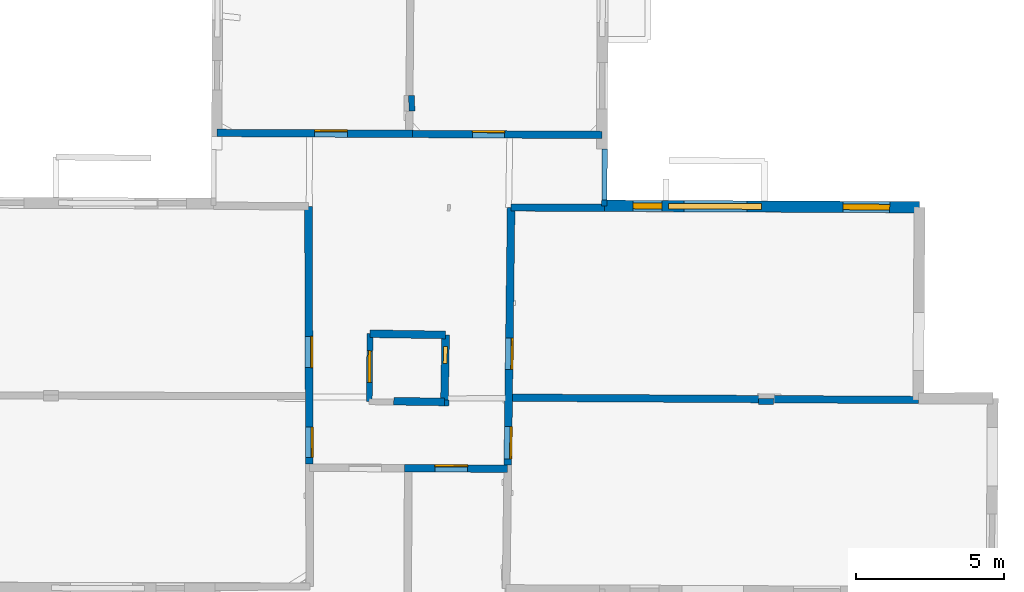
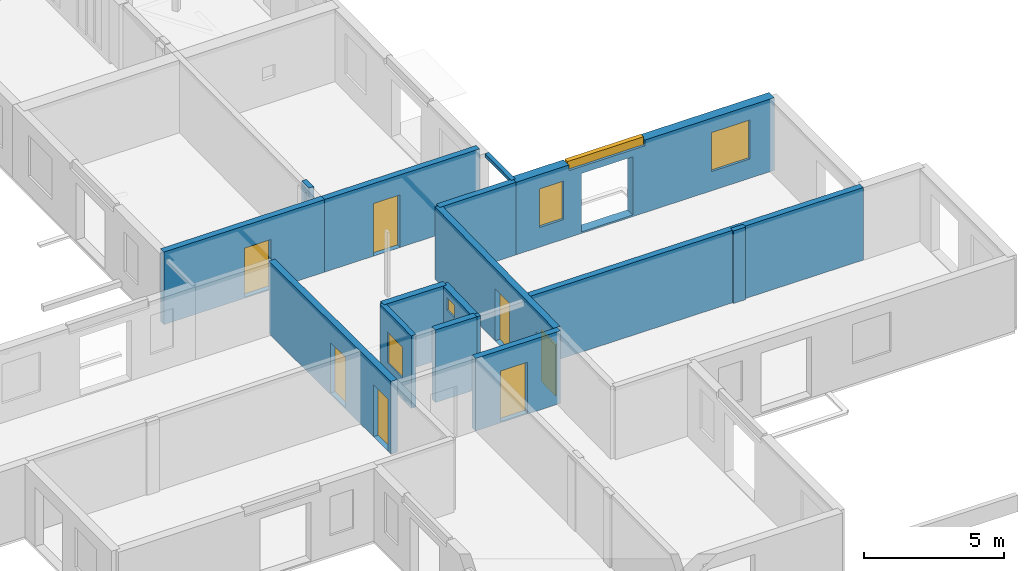
# One storey, part 5 of 17: 16 walls, 7 doors, 5 windows, 14 openings.
"""IFC2X3 building model written with IfcOpenShell, lengths in metres."""

from ifc_helpers import new_model, entity, si_unit, converted_unit, derived_unit, direction, frame, frame_2d, origin, origin_2d_with_axis, place, context, subcontext, project, spatial, polyline, rectangle, outline, extrude, source, transform, mapped, material, layer, layer_set, layer_usage, type_object, type_shapes, element, fill, save


model = new_model("IFC2X3")

# Units and contexts
model_context = context("Model", 3, precision=1e-05, world=origin(), true_north=direction((0.0, 1.0)))
body_context = subcontext(model_context, "Body", "Model", "MODEL_VIEW")
ifc_project = project(units=[si_unit("LENGTHUNIT", "METRE"), si_unit("AREAUNIT", "SQUARE_METRE"), si_unit("VOLUMEUNIT", "CUBIC_METRE"), converted_unit("PLANEANGLEUNIT", "DEGREE", entity("IfcRatioMeasure", 0.0174532925199433), si_unit("PLANEANGLEUNIT", "RADIAN"), dimensions=[0, 0, 0, 0, 0, 0, 0]), si_unit("MASSUNIT", "GRAM", prefix="KILO"), derived_unit("MASSDENSITYUNIT", [(si_unit("MASSUNIT", "GRAM", prefix="KILO"), 1), (si_unit("LENGTHUNIT", "METRE"), -3)]), derived_unit("MOMENTOFINERTIAUNIT", [(si_unit("LENGTHUNIT", "METRE"), 4)]), si_unit("TIMEUNIT", "SECOND"), si_unit("FREQUENCYUNIT", "HERTZ"), si_unit("THERMODYNAMICTEMPERATUREUNIT", "DEGREE_CELSIUS"), derived_unit("THERMALTRANSMITTANCEUNIT", [(si_unit("MASSUNIT", "GRAM", prefix="KILO"), 1), (si_unit("THERMODYNAMICTEMPERATUREUNIT", "KELVIN"), -1), (si_unit("TIMEUNIT", "SECOND"), -3)]), derived_unit("VOLUMETRICFLOWRATEUNIT", [(si_unit("LENGTHUNIT", "METRE"), 3), (si_unit("TIMEUNIT", "SECOND"), -1)]), si_unit("ELECTRICCURRENTUNIT", "AMPERE"), si_unit("ELECTRICVOLTAGEUNIT", "VOLT"), si_unit("POWERUNIT", "WATT"), si_unit("FORCEUNIT", "NEWTON", prefix="KILO"), si_unit("ILLUMINANCEUNIT", "LUX"), si_unit("LUMINOUSFLUXUNIT", "LUMEN"), si_unit("LUMINOUSINTENSITYUNIT", "CANDELA"), derived_unit("USERDEFINED", [(si_unit("MASSUNIT", "GRAM", prefix="KILO"), -1), (si_unit("LENGTHUNIT", "METRE"), -2), (si_unit("TIMEUNIT", "SECOND"), 3), (si_unit("LUMINOUSFLUXUNIT", "LUMEN"), 1)]), derived_unit("LINEARVELOCITYUNIT", [(si_unit("LENGTHUNIT", "METRE"), 1), (si_unit("TIMEUNIT", "SECOND"), -1)]), si_unit("PRESSUREUNIT", "PASCAL"), derived_unit("USERDEFINED", [(si_unit("LENGTHUNIT", "METRE"), -2), (si_unit("MASSUNIT", "GRAM", prefix="KILO"), 1), (si_unit("TIMEUNIT", "SECOND"), -2)]), derived_unit("LINEARFORCEUNIT", [(si_unit("MASSUNIT", "GRAM", prefix="KILO"), 1), (si_unit("LENGTHUNIT", "METRE"), 1), (si_unit("TIMEUNIT", "SECOND"), -2), (si_unit("LENGTHUNIT", "METRE"), -1)]), derived_unit("PLANARFORCEUNIT", [(si_unit("MASSUNIT", "GRAM", prefix="KILO"), 1), (si_unit("LENGTHUNIT", "METRE"), 1), (si_unit("TIMEUNIT", "SECOND"), -2), (si_unit("LENGTHUNIT", "METRE"), -2)])], contexts=[model_context])

# Site, building, storey
placement = place(None, origin())
site = spatial("IfcSite", under=ifc_project, at=placement, CompositionType="ELEMENT")
building = spatial("IfcBuilding", under=site, at=placement, CompositionType="ELEMENT")
storey_placement = place(placement, frame((0.0, 0.0, 5.56662893295288)))
storey = spatial("IfcBuildingStorey", under=building, at=storey_placement, Name="Level 3", CompositionType="ELEMENT", Elevation=5.56662893295288)

# Wall, opening, door
ifc_material_1 = material(Name="Default wall")
ifc_layer_1 = layer(ifc_material_1, 0.25)
ifc_layer_set_1 = layer_set([ifc_layer_1], Name="wall_thickness_0.2500")
ifc_layer_usage_1 = layer_usage(ifc_layer_set_1, "AXIS2", "POSITIVE", -0.125)
wall_type_1 = type_object("IfcWallType", Name="wall_thickness_0.2500", PredefinedType="STANDARD", material=ifc_layer_set_1)
wall_1_placement = place(storey_placement, frame((6.05652333948294, 17.0406184513723, 0.0), z_axis=(0.0, 0.0, 1.0), x_axis=(0.999988302354351, -0.00483685377732667, 0.0)))
wall_1 = element("IfcWallStandardCase", 1, at=wall_1_placement, inside=storey, type_object=wall_type_1, material=ifc_layer_usage_1, Name="Wall:33", ObjectType="Wall", context=body_context, shape_type="SweptSolid", body=[
    extrude(outline(polyline([(3.48278114256136, -0.125), (3.48278114256136, 0.125), (0.0, 0.125), (0.0, -0.125), (3.48278114256136, -0.125)])), origin(), (0.0, 0.0, 1.0), 3.16489877700806),
])
opening_1_placement = place(wall_1_placement, frame((1.02562006761341, -0.125, 0.0583710670471191)))
opening_1 = element("IfcOpeningElement", 2, at=opening_1_placement, cuts=wall_1, Name="Opening : 1105 x 2205 : 26", ObjectType="Opening", context=body_context, shape_type="SweptSolid", body=[
    extrude(rectangle(XDim=1.105, YDim=2.205, at=frame_2d((1.1025, 0.5525), x_axis=(0.0, 1.0))), frame((0.0, 0.0, 0.0), z_axis=(0.0, 1.0, 0.0), x_axis=(0.0, 0.0, 1.0)), (0.0, 0.0, 1.0), 0.25),
])
ifc_material_2 = material(Name="Door Panel")
door_style_1 = type_object("IfcDoorStyle", Name="Door : 1105 x 2205mm", ConstructionType="NOTDEFINED", OperationType="SINGLE_SWING_RIGHT", ParameterTakesPrecedence=False, Sizeable=False, material=ifc_material_2)
shared_shape_1 = source(origin(), body_context, "Body", "SweptSolid", [
    extrude(rectangle(XDim=0.0625, YDim=1.105, at=origin_2d_with_axis()), frame((0.5525, 0.21875, 0.0), z_axis=(0.0, 0.0, 1.0), x_axis=(0.0, 1.0, 0.0)), (0.0, 0.0, 1.0), 2.205),
])
type_shapes(door_style_1, [shared_shape_1])
door_1_placement = place(opening_1_placement, origin())
door_1 = element("IfcDoor", 3, at=door_1_placement, inside=storey, type_object=door_style_1, Name="Door : 1105 x 2205mm : 6", ObjectType="Door : 1105 x 2205mm", OverallHeight=2.205, OverallWidth=1.105, context=body_context, shape_type="MappedRepresentation", body=[
    mapped(shared_shape_1, transform((0.0, 0.0, 0.0), scale=1.0)),
])
fill(opening_1, door_1)

# Wall
wall_2_placement = place(storey_placement, frame((9.65358275442785, 25.8274997320998, 0.0), z_axis=(0.0, 0.0, 1.0), x_axis=(0.999997260642278, -0.00234066399563864, 0.0)))
element("IfcWallStandardCase", 4, at=wall_2_placement, inside=storey, type_object=wall_type_1, material=ifc_layer_usage_1, Name="Wall:60", ObjectType="Wall", context=body_context, shape_type="SweptSolid", body=[
    extrude(outline(polyline([(3.14297297282543, -0.125), (3.14297297282543, 0.125), (0.0, 0.125), (0.0, -0.125), (3.14297297282543, -0.125)])), origin(), (0.0, 0.0, 1.0), 3.16489877700806),
])

# Wall, opening, door
wall_3_placement = place(storey_placement, frame((-0.266225012666625, 28.3407746540219, 0.0), z_axis=(0.0, 0.0, 1.0), x_axis=(0.999985683935674, -0.00535088064734463, 0.0)))
wall_3 = element("IfcWallStandardCase", 5, at=wall_3_placement, inside=storey, type_object=wall_type_1, material=ifc_layer_usage_1, Name="Wall:98", ObjectType="Wall", context=body_context, shape_type="SweptSolid", body=[
    extrude(outline(polyline([(6.60297405283224, -0.125), (6.60297405283224, 0.125), (0.0, 0.125), (0.0, -0.125), (6.60297405283224, -0.125)])), origin(), (0.0, 0.0, 1.0), 3.16489877700806),
])
opening_2_placement = place(wall_3_placement, frame((3.30106026213288, -0.125, 0.0503711700439453)))
opening_2 = element("IfcOpeningElement", 6, at=opening_2_placement, cuts=wall_3, Name="Opening : 1100 x 2140 : 91", ObjectType="Opening", context=body_context, shape_type="SweptSolid", body=[
    extrude(rectangle(XDim=1.1, YDim=2.14, at=frame_2d((1.07, 0.55), x_axis=(0.0, 1.0))), frame((0.0, 0.0, 0.0), z_axis=(0.0, 1.0, 0.0), x_axis=(0.0, 0.0, 1.0)), (0.0, 0.0, 1.0), 0.25),
])
door_style_2 = type_object("IfcDoorStyle", Name="Door : 1100 x 2140mm", ConstructionType="NOTDEFINED", OperationType="SINGLE_SWING_RIGHT", ParameterTakesPrecedence=False, Sizeable=False, material=ifc_material_2)
shared_shape_2 = source(origin(), body_context, "Body", "SweptSolid", [
    extrude(rectangle(XDim=0.0625, YDim=1.1, at=origin_2d_with_axis()), frame((0.55, 0.21875, 0.0), z_axis=(0.0, 0.0, 1.0), x_axis=(0.0, 1.0, 0.0)), (0.0, 0.0, 1.0), 2.14),
])
type_shapes(door_style_2, [shared_shape_2])
door_2_placement = place(opening_2_placement, origin())
door_2 = element("IfcDoor", 7, at=door_2_placement, inside=storey, type_object=door_style_2, Name="Door : 1100 x 2140mm : 13", ObjectType="Door : 1100 x 2140mm", OverallHeight=2.14, OverallWidth=1.1, context=body_context, shape_type="MappedRepresentation", body=[
    mapped(shared_shape_2, transform((0.0, 0.0, 0.0), scale=1.0)),
])
fill(opening_2, door_2)

wall_4_placement = place(storey_placement, frame((6.33665451156433, 28.3054429279477, 0.0), z_axis=(0.0, 0.0, 1.0), x_axis=(0.999985684537031, -0.00535076826313938, 0.0)))
wall_4 = element("IfcWallStandardCase", 8, at=wall_4_placement, inside=storey, type_object=wall_type_1, material=ifc_layer_usage_1, Name="Wall:99", ObjectType="Wall", context=body_context, shape_type="SweptSolid", body=[
    extrude(outline(polyline([(6.37711546509686, -0.125), (6.37711546509686, 0.125), (0.0, 0.125), (0.0, -0.125), (6.37711546509686, -0.125)])), origin(), (0.0, 0.0, 1.0), 3.16489877700806),
])
opening_3_placement = place(wall_4_placement, frame((2.00841869315561, -0.125, 0.00537109375)))
opening_3 = element("IfcOpeningElement", 9, at=opening_3_placement, cuts=wall_4, Name="Opening : 1090 x 2290 : 92", ObjectType="Opening", context=body_context, shape_type="SweptSolid", body=[
    extrude(rectangle(XDim=1.09, YDim=2.29, at=frame_2d((1.145, 0.545), x_axis=(0.0, 1.0))), frame((0.0, 0.0, 0.0), z_axis=(0.0, 1.0, 0.0), x_axis=(0.0, 0.0, 1.0)), (0.0, 0.0, 1.0), 0.25),
])
door_style_3 = type_object("IfcDoorStyle", Name="Door : 1090 x 2290mm", ConstructionType="NOTDEFINED", OperationType="SINGLE_SWING_RIGHT", ParameterTakesPrecedence=False, Sizeable=False, material=ifc_material_2)
shared_shape_3 = source(origin(), body_context, "Body", "SweptSolid", [
    extrude(rectangle(XDim=0.0625, YDim=1.09, at=origin_2d_with_axis()), frame((0.545, 0.21875, 0.0), z_axis=(0.0, 0.0, 1.0), x_axis=(0.0, 1.0, 0.0)), (0.0, 0.0, 1.0), 2.29),
])
type_shapes(door_style_3, [shared_shape_3])
door_3_placement = place(opening_3_placement, origin())
door_3 = element("IfcDoor", 10, at=door_3_placement, inside=storey, type_object=door_style_3, Name="Door : 1090 x 2290mm : 14", ObjectType="Door : 1090 x 2290mm", OverallHeight=2.29, OverallWidth=1.09, context=body_context, shape_type="MappedRepresentation", body=[
    mapped(shared_shape_3, transform((0.0, 0.0, 0.0), scale=1.0)),
])
fill(opening_3, door_3)

# Wall
wall_5_placement = place(storey_placement, frame((9.62779988573269, 19.4185865706265, 0.0), z_axis=(0.0, 0.0, 1.0), x_axis=(0.999983458236954, -0.00575180427886315, 0.0)))
element("IfcWallStandardCase", 11, at=wall_5_placement, inside=storey, type_object=wall_type_1, material=ifc_layer_usage_1, Name="Wall:112", ObjectType="Wall", context=body_context, shape_type="SweptSolid", body=[
    extrude(outline(polyline([(13.7478355982533, -0.125), (13.7478355982533, 0.125), (0.0, 0.125), (0.0, -0.125), (13.7478355982533, -0.125)])), origin(), (0.0, 0.0, 1.0), 3.16489877700806),
])

# Wall, opening, window
ifc_layer_2 = layer(ifc_material_1, 0.2)
ifc_layer_set_2 = layer_set([ifc_layer_2], Name="wall_thickness_0.2000")
ifc_layer_usage_2 = layer_usage(ifc_layer_set_2, "AXIS2", "POSITIVE", -0.1)
wall_type_2 = type_object("IfcWallType", Name="wall_thickness_0.2000", PredefinedType="STANDARD", material=ifc_layer_set_2)
wall_6_placement = place(storey_placement, frame((4.89663860121221, 21.5726538806311, 0.0), z_axis=(0.0, 0.0, 1.0), x_axis=(-0.0110328218445975, -0.999939136568894, 0.0)))
wall_6 = element("IfcWallStandardCase", 12, at=wall_6_placement, inside=storey, type_object=wall_type_2, material=ifc_layer_usage_2, Name="Wall:6", ObjectType="Wall", context=body_context, shape_type="SweptSolid", body=[
    extrude(outline(polyline([(2.29026428653109, -0.1), (2.29026428653109, 0.1), (0.0, 0.1), (0.0, -0.1), (2.29026428653109, -0.1)])), origin(), (0.0, 0.0, 1.0), 3.16489877700806),
])
opening_4_placement = place(wall_6_placement, frame((0.573237012092791, -0.1, 0.935370922088623)))
opening_4 = element("IfcOpeningElement", 13, at=opening_4_placement, cuts=wall_6, Name="Opening : 1075 x 1345 : 6", ObjectType="Opening", context=body_context, shape_type="SweptSolid", body=[
    extrude(rectangle(XDim=1.075, YDim=1.345, at=frame_2d((0.6725, 0.5375), x_axis=(0.0, 1.0))), frame((0.0, 0.0, 0.0), z_axis=(0.0, 1.0, 0.0), x_axis=(0.0, 0.0, 1.0)), (0.0, 0.0, 1.0), 0.2),
])
ifc_material_3 = material(Name="Window Default")
window_style_1 = type_object("IfcWindowStyle", Name="Window : 1075 x 1345mm", ConstructionType="NOTDEFINED", OperationType="NOTDEFINED", ParameterTakesPrecedence=False, Sizeable=False, material=ifc_material_3)
shared_shape_4 = source(origin(), body_context, "Body", "SweptSolid", [
    extrude(rectangle(XDim=0.1, YDim=1.075, at=origin_2d_with_axis()), frame((0.5375, 0.1, 0.0), z_axis=(0.0, 0.0, 1.0), x_axis=(0.0, 1.0, 0.0)), (0.0, 0.0, 1.0), 1.345),
])
type_shapes(window_style_1, [shared_shape_4])
window_1_placement = place(opening_4_placement, origin())
window_1 = element("IfcWindow", 14, at=window_1_placement, inside=storey, type_object=window_style_1, Name="Window : 1075 x 1345mm : 3", ObjectType="Window : 1075 x 1345mm", OverallHeight=1.345, OverallWidth=1.075, context=body_context, shape_type="MappedRepresentation", body=[
    mapped(shared_shape_4, transform((0.0, 0.0, 0.0), scale=1.0)),
])
fill(opening_4, window_1)

# Walls
wall_7_placement = place(storey_placement, frame((6.29950273204729, 29.6028762948061, 0.0), z_axis=(0.0, 0.0, 1.0), x_axis=(0.0174559220845369, -0.999847633784357, 0.0)))
element("IfcWallStandardCase", 15, at=wall_7_placement, inside=storey, type_object=wall_type_2, material=ifc_layer_usage_2, Name="Wall:59", ObjectType="Wall", context=body_context, shape_type="SweptSolid", body=[
    extrude(outline(polyline([(0.519999579489156, -0.1), (0.519999579489156, 0.1), (0.0, 0.1), (0.0, -0.1), (0.519999579489156, -0.1)])), origin(), (0.0, 0.0, 1.0), 3.16489877700806),
])
wall_8_placement = place(storey_placement, frame((7.40559188603912, 19.244619245021, 0.0), z_axis=(0.0, 0.0, 1.0), x_axis=(0.999887880909384, -0.0149741647693876, 0.0)))
element("IfcWallStandardCase", 16, at=wall_8_placement, inside=storey, type_object=wall_type_2, material=ifc_layer_usage_2, Name="Wall:85", ObjectType="Wall", context=body_context, shape_type="SweptSolid", body=[
    extrude(outline(polyline([(0.147373987274104, -0.1), (0.147373987274104, 0.1), (0.0, 0.1), (0.0, -0.1), (0.147373987274104, -0.1)])), origin(), (0.0, 0.0, 1.0), 3.16489877700806),
])
wall_9_placement = place(storey_placement, frame((17.9935772495763, 19.2877926536209, 0.0), z_axis=(0.0, 0.0, 1.0), x_axis=(0.999951072346888, -0.00989206309671327, 0.0)))
element("IfcWallStandardCase", 17, at=wall_9_placement, inside=storey, type_object=wall_type_2, material=ifc_layer_usage_2, Name="Wall:116", ObjectType="Wall", context=body_context, shape_type="SweptSolid", body=[
    extrude(outline(polyline([(0.509998479029646, -0.1), (0.509998479029646, 0.1), (0.0, 0.1), (0.0, -0.1), (0.509998479029646, -0.1)])), origin(), (0.0, 0.0, 1.0), 3.16489877700806),
])

# Wall, opening, window
ifc_layer_3 = layer(ifc_material_1, 0.259999990463257)
ifc_layer_set_3 = layer_set([ifc_layer_3], Name="wall_thickness_0.2600")
ifc_layer_usage_3 = layer_usage(ifc_layer_set_3, "AXIS2", "POSITIVE", -0.129999995231628)
wall_type_3 = type_object("IfcWallType", Name="wall_thickness_0.2600", PredefinedType="STANDARD", material=ifc_layer_set_3)
wall_10_placement = place(storey_placement, frame((7.44738352803306, 21.5320929969536, 0.0), z_axis=(0.0, 0.0, 1.0), x_axis=(-0.0182664199191456, -0.999833155033047, 0.0)))
wall_10 = element("IfcWallStandardCase", 18, at=wall_10_placement, inside=storey, type_object=wall_type_3, material=ifc_layer_usage_3, Name="Wall:57", ObjectType="Wall", context=body_context, shape_type="SweptSolid", body=[
    extrude(outline(polyline([(2.28785730341368, -0.129999995231628), (2.28785730341368, 0.129999995231628), (0.0, 0.129999995231628), (0.0, -0.129999995231628), (2.28785730341368, -0.129999995231628)])), origin(), (0.0, 0.0, 1.0), 3.16489877700806),
])
opening_5_placement = place(wall_10_placement, frame((0.386357795329714, -0.129999995231628, 2.27537107467651)))
opening_5 = element("IfcOpeningElement", 19, at=opening_5_placement, cuts=wall_10, Name="Opening : 570 x 555 : 57", ObjectType="Opening", context=body_context, shape_type="SweptSolid", body=[
    extrude(rectangle(XDim=0.57, YDim=0.555, at=frame_2d((0.2775, 0.285), x_axis=(0.0, 1.0))), frame((0.0, 0.0, 0.0), z_axis=(0.0, 1.0, 0.0), x_axis=(0.0, 0.0, 1.0)), (0.0, 0.0, 1.0), 0.259999990463257),
])
window_style_2 = type_object("IfcWindowStyle", Name="Window : 570 x 555mm", ConstructionType="NOTDEFINED", OperationType="NOTDEFINED", ParameterTakesPrecedence=False, Sizeable=False, material=ifc_material_3)
shared_shape_5 = source(origin(), body_context, "Body", "SweptSolid", [
    extrude(rectangle(XDim=0.129999995231628, YDim=0.57, at=origin_2d_with_axis()), frame((0.285, 0.129999995231628, 0.0), z_axis=(0.0, 0.0, 1.0), x_axis=(0.0, 1.0, 0.0)), (0.0, 0.0, 1.0), 0.555),
])
type_shapes(window_style_2, [shared_shape_5])
window_2_placement = place(opening_5_placement, origin())
window_2 = element("IfcWindow", 20, at=window_2_placement, inside=storey, type_object=window_style_2, Name="Window : 570 x 555mm : 35", ObjectType="Window : 570 x 555mm", OverallHeight=0.555, OverallWidth=0.57, context=body_context, shape_type="MappedRepresentation", body=[
    mapped(shared_shape_5, transform((0.0, 0.0, 0.0), scale=1.0)),
])
fill(opening_5, window_2)

# Walls
wall_11_placement = place(storey_placement, frame((5.69767098467866, 19.2992242456948, 0.0), z_axis=(0.0, 0.0, 1.0), x_axis=(0.999880890194996, -0.0154339049777772, 0.0)))
element("IfcWallStandardCase", 21, at=wall_11_placement, inside=storey, type_object=wall_type_3, material=ifc_layer_usage_3, Name="Wall:77", ObjectType="Wall", context=body_context, shape_type="SweptSolid", body=[
    extrude(outline(polyline([(1.70864095867095, -0.129999995231628), (1.70864095867095, 0.129999995231628), (0.0, 0.129999995231628), (0.0, -0.129999995231628), (1.70864095867095, -0.129999995231628)])), origin(), (0.0, 0.0, 1.0), 3.16489877700806),
])
wall_12_placement = place(storey_placement, frame((4.8966382599595, 21.5726543843913, 0.0), z_axis=(0.0, 0.0, 1.0), x_axis=(0.999873588956498, -0.0158998775860842, 0.0)))
element("IfcWallStandardCase", 22, at=wall_12_placement, inside=storey, type_object=wall_type_3, material=ifc_layer_usage_3, Name="Wall:87", ObjectType="Wall", context=body_context, shape_type="SweptSolid", body=[
    extrude(outline(polyline([(2.55106844727476, -0.129999995231628), (2.55106844727476, 0.129999995231628), (0.0, 0.129999995231628), (0.0, -0.129999995231628), (2.55106844727476, -0.129999995231628)])), origin(), (0.0, 0.0, 1.0), 3.16489877700806),
])

# Wall, openings, doors
wall_13_placement = place(storey_placement, frame((9.65358293895707, 25.8274975332237, 0.0), z_axis=(0.0, 0.0, 1.0), x_axis=(-0.0129842757442071, -0.999915700738516, 0.0)))
wall_13 = element("IfcWallStandardCase", 23, at=wall_13_placement, inside=storey, type_object=wall_type_3, material=ifc_layer_usage_3, Name="Wall:96", ObjectType="Wall", context=body_context, shape_type="SweptSolid", body=[
    extrude(outline(polyline([(8.67947122074347, -0.129999995231628), (8.67947122074347, 0.129999995231628), (0.0, 0.129999995231628), (0.0, -0.129999995231628), (8.67947122074347, -0.129999995231628)])), origin(), (0.0, 0.0, 1.0), 3.16489877700806),
])
opening_6_placement = place(wall_13_placement, frame((4.40264624047933, -0.129999995231628, 0.00537109375)))
opening_6 = element("IfcOpeningElement", 24, at=opening_6_placement, cuts=wall_13, Name="Opening : 1055 x 2275 : 89", ObjectType="Opening", context=body_context, shape_type="SweptSolid", body=[
    extrude(rectangle(XDim=1.055, YDim=2.275, at=frame_2d((1.1375, 0.5275), x_axis=(0.0, 1.0))), frame((0.0, 0.0, 0.0), z_axis=(0.0, 1.0, 0.0), x_axis=(0.0, 0.0, 1.0)), (0.0, 0.0, 1.0), 0.259999990463257),
])
opening_7_placement = place(wall_13_placement, frame((7.38857185155388, -0.129999995231628, 0.00537109375)))
opening_7 = element("IfcOpeningElement", 25, at=opening_7_placement, cuts=wall_13, Name="Opening : 1085 x 2230 : 90", ObjectType="Opening", context=body_context, shape_type="SweptSolid", body=[
    extrude(rectangle(XDim=1.085, YDim=2.23, at=frame_2d((1.115, 0.5425), x_axis=(0.0, 1.0))), frame((0.0, 0.0, 0.0), z_axis=(0.0, 1.0, 0.0), x_axis=(0.0, 0.0, 1.0)), (0.0, 0.0, 1.0), 0.259999990463257),
])
door_style_4 = type_object("IfcDoorStyle", Name="Door : 1055 x 2275mm", ConstructionType="NOTDEFINED", OperationType="SINGLE_SWING_RIGHT", ParameterTakesPrecedence=False, Sizeable=False, material=ifc_material_2)
shared_shape_6 = source(origin(), body_context, "Body", "SweptSolid", [
    extrude(rectangle(XDim=0.0649999976158142, YDim=1.055, at=origin_2d_with_axis()), frame((0.5275, 0.22749999165535, 0.0), z_axis=(0.0, 0.0, 1.0), x_axis=(0.0, 1.0, 0.0)), (0.0, 0.0, 1.0), 2.275),
])
type_shapes(door_style_4, [shared_shape_6])
door_4_placement = place(opening_6_placement, origin())
door_4 = element("IfcDoor", 26, at=door_4_placement, inside=storey, type_object=door_style_4, Name="Door : 1055 x 2275mm : 11", ObjectType="Door : 1055 x 2275mm", OverallHeight=2.275, OverallWidth=1.055, context=body_context, shape_type="MappedRepresentation", body=[
    mapped(shared_shape_6, transform((0.0, 0.0, 0.0), scale=1.0)),
])
fill(opening_6, door_4)
door_style_5 = type_object("IfcDoorStyle", Name="Door : 1085 x 2230mm", ConstructionType="NOTDEFINED", OperationType="SINGLE_SWING_RIGHT", ParameterTakesPrecedence=False, Sizeable=False, material=ifc_material_2)
shared_shape_7 = source(origin(), body_context, "Body", "SweptSolid", [
    extrude(rectangle(XDim=0.0649999976158142, YDim=1.085, at=origin_2d_with_axis()), frame((0.5425, 0.22749999165535, 0.0), z_axis=(0.0, 0.0, 1.0), x_axis=(0.0, 1.0, 0.0)), (0.0, 0.0, 1.0), 2.23),
])
type_shapes(door_style_5, [shared_shape_7])
door_5_placement = place(opening_7_placement, origin())
door_5 = element("IfcDoor", 27, at=door_5_placement, inside=storey, type_object=door_style_5, Name="Door : 1085 x 2230mm : 12", ObjectType="Door : 1085 x 2230mm", OverallHeight=2.23, OverallWidth=1.085, context=body_context, shape_type="MappedRepresentation", body=[
    mapped(shared_shape_7, transform((0.0, 0.0, 0.0), scale=1.0)),
])
fill(opening_7, door_5)

wall_14_placement = place(storey_placement, frame((2.82302478756025, 25.8640695981622, 0.0), z_axis=(0.0, 0.0, 1.0), x_axis=(0.00366327981519311, -0.999993290167987, 0.0)))
wall_14 = element("IfcWallStandardCase", 28, at=wall_14_placement, inside=storey, type_object=wall_type_3, material=ifc_layer_usage_3, Name="Wall:117", ObjectType="Wall", context=body_context, shape_type="SweptSolid", body=[
    extrude(outline(polyline([(8.68303212338125, -0.129999995231628), (8.68303212338125, 0.129999995231628), (0.0, 0.129999995231628), (0.0, -0.129999995231628), (8.68303212338125, -0.129999995231628)])), origin(), (0.0, 0.0, 1.0), 3.16489877700806),
])
opening_8_placement = place(wall_14_placement, frame((4.38113291404856, -0.129999995231628, 0.0623712539672852)))
opening_8 = element("IfcOpeningElement", 29, at=opening_8_placement, cuts=wall_14, Name="Opening : 1055 x 2200 : 108", ObjectType="Opening", context=body_context, shape_type="SweptSolid", body=[
    extrude(rectangle(XDim=1.055, YDim=2.2, at=frame_2d((1.1, 0.5275), x_axis=(0.0, 1.0))), frame((0.0, 0.0, 0.0), z_axis=(0.0, 1.0, 0.0), x_axis=(0.0, 0.0, 1.0)), (0.0, 0.0, 1.0), 0.259999990463257),
])
opening_9_placement = place(wall_14_placement, frame((7.43507415174156, -0.129999995231628, 0.00537109375)))
opening_9 = element("IfcOpeningElement", 30, at=opening_9_placement, cuts=wall_14, Name="Opening : 1020 x 2255 : 109", ObjectType="Opening", context=body_context, shape_type="SweptSolid", body=[
    extrude(rectangle(XDim=1.02, YDim=2.255, at=frame_2d((1.1275, 0.51), x_axis=(0.0, 1.0))), frame((0.0, 0.0, 0.0), z_axis=(0.0, 1.0, 0.0), x_axis=(0.0, 0.0, 1.0)), (0.0, 0.0, 1.0), 0.259999990463257),
])
door_style_6 = type_object("IfcDoorStyle", Name="Door : 1055 x 2200mm", ConstructionType="NOTDEFINED", OperationType="SINGLE_SWING_RIGHT", ParameterTakesPrecedence=False, Sizeable=False, material=ifc_material_2)
shared_shape_8 = source(origin(), body_context, "Body", "SweptSolid", [
    extrude(rectangle(XDim=0.0649999976158142, YDim=1.055, at=origin_2d_with_axis()), frame((0.5275, 0.22749999165535, 0.0), z_axis=(0.0, 0.0, 1.0), x_axis=(0.0, 1.0, 0.0)), (0.0, 0.0, 1.0), 2.2),
])
type_shapes(door_style_6, [shared_shape_8])
door_6_placement = place(opening_8_placement, origin())
door_6 = element("IfcDoor", 31, at=door_6_placement, inside=storey, type_object=door_style_6, Name="Door : 1055 x 2200mm : 15", ObjectType="Door : 1055 x 2200mm", OverallHeight=2.2, OverallWidth=1.055, context=body_context, shape_type="MappedRepresentation", body=[
    mapped(shared_shape_8, transform((0.0, 0.0, 0.0), scale=1.0)),
])
fill(opening_8, door_6)
door_style_7 = type_object("IfcDoorStyle", Name="Door : 1020 x 2255mm", ConstructionType="NOTDEFINED", OperationType="SINGLE_SWING_RIGHT", ParameterTakesPrecedence=False, Sizeable=False, material=ifc_material_2)
shared_shape_9 = source(origin(), body_context, "Body", "SweptSolid", [
    extrude(rectangle(XDim=0.0649999976158142, YDim=1.02, at=origin_2d_with_axis()), frame((0.51, 0.22749999165535, 0.0), z_axis=(0.0, 0.0, 1.0), x_axis=(0.0, 1.0, 0.0)), (0.0, 0.0, 1.0), 2.255),
])
type_shapes(door_style_7, [shared_shape_9])
door_7_placement = place(opening_9_placement, origin())
door_7 = element("IfcDoor", 32, at=door_7_placement, inside=storey, type_object=door_style_7, Name="Door : 1020 x 2255mm : 16", ObjectType="Door : 1020 x 2255mm", OverallHeight=2.255, OverallWidth=1.02, context=body_context, shape_type="MappedRepresentation", body=[
    mapped(shared_shape_9, transform((0.0, 0.0, 0.0), scale=1.0)),
])
fill(opening_9, door_7)

# Wall, openings, windows
ifc_layer_4 = layer(ifc_material_1, 0.379999995231628)
ifc_layer_set_4 = layer_set([ifc_layer_4], Name="wall_thickness_0.3800")
ifc_layer_usage_4 = layer_usage(ifc_layer_set_4, "AXIS2", "POSITIVE", -0.189999997615814)
wall_type_4 = type_object("IfcWallType", Name="wall_thickness_0.3800", PredefinedType="STANDARD", material=ifc_layer_set_4)
wall_15_placement = place(storey_placement, frame((12.7968644985486, 25.884619449475, 0.0), z_axis=(0.0, 0.0, 1.0), x_axis=(0.999989151670388, -0.00465795465166729, 0.0)))
wall_15 = element("IfcWallStandardCase", 33, at=wall_15_placement, inside=storey, type_object=wall_type_4, material=ifc_layer_usage_4, Name="Wall:50", ObjectType="Wall", context=body_context, shape_type="SweptSolid", body=[
    extrude(outline(polyline([(10.6219633369437, -0.189999997615814), (10.6219633369437, 0.189999997615814), (0.0, 0.189999997615814), (0.0, -0.189999997615814), (10.6219633369437, -0.189999997615814)])), origin(), (0.0, 0.0, 1.0), 3.16489877700806),
])
opening_10_placement = place(wall_15_placement, frame((2.68951950361551, -0.189999997615814, 0.0713710784912109)))
element("IfcOpeningElement", 34, at=opening_10_placement, cuts=wall_15, Name="Opening : 2110 x 2540 : 36", ObjectType="Opening", context=body_context, shape_type="SweptSolid", body=[
    extrude(rectangle(XDim=2.11, YDim=2.54, at=frame_2d((1.27, 1.055), x_axis=(0.0, 1.0))), frame((0.0, 0.0, 0.0), z_axis=(0.0, 1.0, 0.0), x_axis=(0.0, 0.0, 1.0)), (0.0, 0.0, 1.0), 0.379999995231628),
])
opening_11_placement = place(wall_15_placement, frame((2.16571012976675, -0.189999997615814, 2.91537141799927)))
opening_11 = element("IfcOpeningElement", 35, at=opening_11_placement, cuts=wall_15, Name="Opening : 3125 x 340 : 37", ObjectType="Opening", context=body_context, shape_type="SweptSolid", body=[
    extrude(rectangle(XDim=3.125, YDim=0.34, at=frame_2d((0.17, 1.5625), x_axis=(0.0, 1.0))), frame((0.0, 0.0, 0.0), z_axis=(0.0, 1.0, 0.0), x_axis=(0.0, 0.0, 1.0)), (0.0, 0.0, 1.0), 0.379999995231628),
])
opening_12_placement = place(wall_15_placement, frame((8.04167984916201, -0.189999997615814, 0.840371131896973)))
opening_12 = element("IfcOpeningElement", 36, at=opening_12_placement, cuts=wall_15, Name="Opening : 1575 x 1700 : 38", ObjectType="Opening", context=body_context, shape_type="SweptSolid", body=[
    extrude(rectangle(XDim=1.575, YDim=1.7, at=frame_2d((0.85, 0.7875), x_axis=(0.0, 1.0))), frame((0.0, 0.0, 0.0), z_axis=(0.0, 1.0, 0.0), x_axis=(0.0, 0.0, 1.0)), (0.0, 0.0, 1.0), 0.379999995231628),
])
opening_13_placement = place(wall_15_placement, frame((0.961679414448412, -0.189999997615814, 0.860371112823486)))
opening_13 = element("IfcOpeningElement", 37, at=opening_13_placement, cuts=wall_15, Name="Opening : 985 x 1680 : 39", ObjectType="Opening", context=body_context, shape_type="SweptSolid", body=[
    extrude(rectangle(XDim=0.985, YDim=1.68, at=frame_2d((0.84, 0.4925), x_axis=(0.0, 1.0))), frame((0.0, 0.0, 0.0), z_axis=(0.0, 1.0, 0.0), x_axis=(0.0, 0.0, 1.0)), (0.0, 0.0, 1.0), 0.379999995231628),
])
window_style_3 = type_object("IfcWindowStyle", Name="Window : 3125 x 340mm", ConstructionType="NOTDEFINED", OperationType="NOTDEFINED", ParameterTakesPrecedence=False, Sizeable=False, material=ifc_material_3)
shared_shape_10 = source(origin(), body_context, "Body", "SweptSolid", [
    extrude(rectangle(XDim=0.189999997615814, YDim=3.125, at=origin_2d_with_axis()), frame((1.5625, 0.189999997615814, 0.0), z_axis=(0.0, 0.0, 1.0), x_axis=(0.0, 1.0, 0.0)), (0.0, 0.0, 1.0), 0.34),
])
type_shapes(window_style_3, [shared_shape_10])
window_3_placement = place(opening_11_placement, origin())
window_3 = element("IfcWindow", 38, at=window_3_placement, inside=storey, type_object=window_style_3, Name="Window : 3125 x 340mm : 19", ObjectType="Window : 3125 x 340mm", OverallHeight=0.34, OverallWidth=3.125, context=body_context, shape_type="MappedRepresentation", body=[
    mapped(shared_shape_10, transform((0.0, 0.0, 0.0), scale=1.0)),
])
fill(opening_11, window_3)
window_style_4 = type_object("IfcWindowStyle", Name="Window : 1575 x 1700mm", ConstructionType="NOTDEFINED", OperationType="NOTDEFINED", ParameterTakesPrecedence=False, Sizeable=False, material=ifc_material_3)
shared_shape_11 = source(origin(), body_context, "Body", "SweptSolid", [
    extrude(rectangle(XDim=0.189999997615814, YDim=1.575, at=origin_2d_with_axis()), frame((0.7875, 0.189999997615814, 0.0), z_axis=(0.0, 0.0, 1.0), x_axis=(0.0, 1.0, 0.0)), (0.0, 0.0, 1.0), 1.7),
])
type_shapes(window_style_4, [shared_shape_11])
window_4_placement = place(opening_12_placement, origin())
window_4 = element("IfcWindow", 39, at=window_4_placement, inside=storey, type_object=window_style_4, Name="Window : 1575 x 1700mm : 20", ObjectType="Window : 1575 x 1700mm", OverallHeight=1.7, OverallWidth=1.575, context=body_context, shape_type="MappedRepresentation", body=[
    mapped(shared_shape_11, transform((0.0, 0.0, 0.0), scale=1.0)),
])
fill(opening_12, window_4)
window_style_5 = type_object("IfcWindowStyle", Name="Window : 985 x 1680mm", ConstructionType="NOTDEFINED", OperationType="NOTDEFINED", ParameterTakesPrecedence=False, Sizeable=False, material=ifc_material_3)
shared_shape_12 = source(origin(), body_context, "Body", "SweptSolid", [
    extrude(rectangle(XDim=0.189999997615814, YDim=0.985, at=origin_2d_with_axis()), frame((0.4925, 0.189999997615814, 0.0), z_axis=(0.0, 0.0, 1.0), x_axis=(0.0, 1.0, 0.0)), (0.0, 0.0, 1.0), 1.68),
])
type_shapes(window_style_5, [shared_shape_12])
window_5_placement = place(opening_13_placement, origin())
window_5 = element("IfcWindow", 40, at=window_5_placement, inside=storey, type_object=window_style_5, Name="Window : 985 x 1680mm : 21", ObjectType="Window : 985 x 1680mm", OverallHeight=1.68, OverallWidth=0.985, context=body_context, shape_type="MappedRepresentation", body=[
    mapped(shared_shape_12, transform((0.0, 0.0, 0.0), scale=1.0)),
])
fill(opening_13, window_5)

# Wall, opening
ifc_layer_5 = layer(ifc_material_1, 0.180000007152557)
ifc_layer_set_5 = layer_set([ifc_layer_5], Name="wall_thickness_0.1800")
ifc_layer_usage_5 = layer_usage(ifc_layer_set_5, "AXIS2", "POSITIVE", -0.0900000035762787)
wall_type_5 = type_object("IfcWallType", Name="wall_thickness_0.1800", PredefinedType="STANDARD", material=ifc_layer_set_5)
wall_16_placement = place(storey_placement, frame((12.8063204877422, 27.7950964013845, 0.0), z_axis=(0.0, 0.0, 1.0), x_axis=(-0.00494881828836327, -0.999987754523799, 0.0)))
wall_16 = element("IfcWallStandardCase", 41, at=wall_16_placement, inside=storey, type_object=wall_type_5, material=ifc_layer_usage_5, Name="Wall:54", ObjectType="Wall", context=body_context, shape_type="SweptSolid", body=[
    extrude(outline(polyline([(1.91050198692556, -0.0900000035762787), (1.91050198692556, 0.0900000035762787), (0.0, 0.0900000035762787), (0.0, -0.0900000035762787), (1.91050198692556, -0.0900000035762787)])), origin(), (0.0, 0.0, 1.0), 3.16489877700806),
])
opening_14_placement = place(wall_16_placement, frame((-0.25416878590905, -0.0900000035762787, 0.00537109375)))
element("IfcOpeningElement", 42, at=opening_14_placement, cuts=wall_16, Name="Opening : 1965 x 3010 : 49", ObjectType="Opening", context=body_context, shape_type="SweptSolid", body=[
    extrude(rectangle(XDim=1.965, YDim=3.01, at=frame_2d((1.505, 0.9825), x_axis=(0.0, 1.0))), frame((0.0, 0.0, 0.0), z_axis=(0.0, 1.0, 0.0), x_axis=(0.0, 0.0, 1.0)), (0.0, 0.0, 1.0), 0.180000007152557),
])

save(model, "model.ifc")
